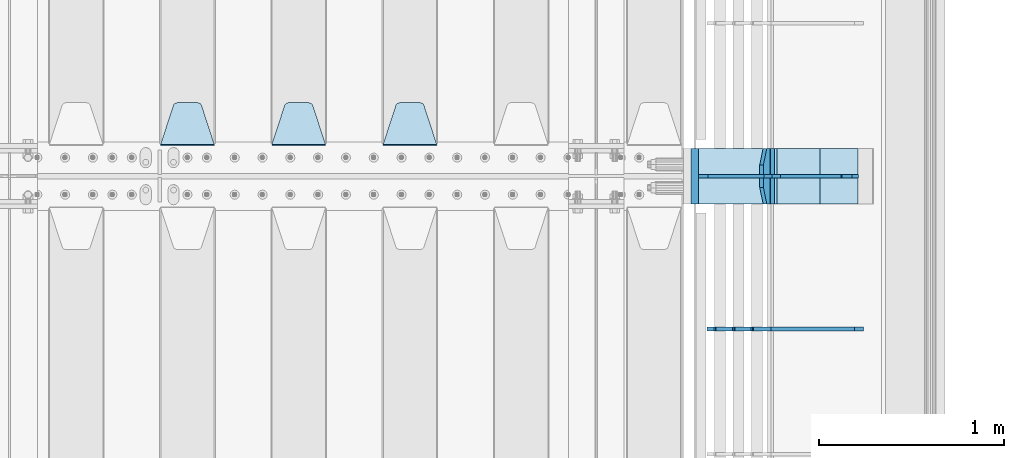
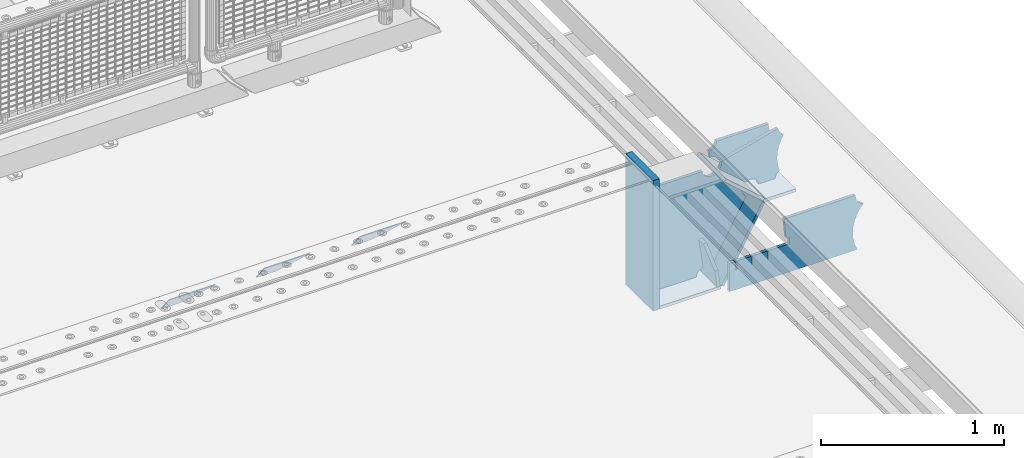
# One storey, part 221 of 240: 13 plates.
"""IFC2X3 building model written with IfcOpenShell, lengths in millimetres."""

from ifc_helpers import new_model, si_unit, frame, origin_with_axes, place, context, subcontext, project, spatial, faceted_brep, material, type_object, element, save


model = new_model("IFC2X3")

# Units and contexts
model_context = context("Model", 3, precision=1e-05, world=origin_with_axes())
body_context = subcontext(model_context, "Body", "Model", "MODEL_VIEW")
ifc_project = project(units=[si_unit("LENGTHUNIT", "METRE", prefix="MILLI"), si_unit("AREAUNIT", "SQUARE_METRE"), si_unit("VOLUMEUNIT", "CUBIC_METRE"), si_unit("MASSUNIT", "GRAM", prefix="KILO"), si_unit("TIMEUNIT", "SECOND"), si_unit("PLANEANGLEUNIT", "RADIAN"), si_unit("SOLIDANGLEUNIT", "STERADIAN"), si_unit("THERMODYNAMICTEMPERATUREUNIT", "DEGREE_CELSIUS"), si_unit("LUMINOUSINTENSITYUNIT", "LUMEN")], contexts=[model_context])

# Site, building, storey
site_placement = place(None, origin_with_axes())
site = spatial("IfcSite", under=ifc_project, at=site_placement, CompositionType="ELEMENT")
building_placement = place(site_placement, origin_with_axes())
building = spatial("IfcBuilding", under=site, at=building_placement, Name="Standard", CompositionType="ELEMENT")
storey_placement = place(building_placement, origin_with_axes())
storey = spatial("IfcBuildingStorey", under=building, at=storey_placement, Name="Undefined", CompositionType="ELEMENT", Elevation=0.0)

# Plates
ifc_material_1 = material(Name="STEEL/S355N")
plate_type_1 = type_object("IfcPlateType", PredefinedType="NOTDEFINED")
plate_1_placement = place(storey_placement, frame((55145.0, 33168.232233047, -1.76776695296758), z_axis=(0.0, 0.707106781186547, -0.707106781186548), x_axis=(-1.0, 0.0, 0.0)))
element("IfcPlate", 1, at=plate_1_placement, inside=storey, type_object=plate_type_1, material=ifc_material_1, context=body_context, shape_type="Brep", body=[
    faceted_brep([(0.0, -2.5, 0.0), (69.345504679477, -2.50000000000364, 300.171731424827), (69.345504679477, 2.49999999999636, 300.171731424827), (0.0, 2.5, 0.0), (70.927406119954, -2.50000000000364, 304.897442415397), (70.927406119954, 2.49999999999636, 304.897442415397), (73.3818627772271, -2.50000000000728, 309.234538108525), (73.3818627772271, 2.49999999999636, 309.234538108529), (76.6187032999587, -2.50000000000728, 313.023683126099), (76.6187032999587, 2.49999999999636, 313.023683126103), (80.5190132705029, -2.50000000000364, 316.125672595368), (80.5190132705029, 2.49999999999636, 316.125672595368), (84.9395038596849, -2.50000000000364, 318.426546230472), (84.9395038596849, 2.49999999999636, 318.426546230472), (89.7177759439219, -2.5, 319.841774983277), (89.7177759439219, 2.49999999999636, 319.841774983273), (94.6782862926484, -2.50000000000364, 320.319366455074), (94.6782862926484, 2.49999999999636, 320.319366455074), (195.321713707352, -2.50000000000364, 320.319366455074), (195.321713707352, 2.49999999999636, 320.319366455074), (200.282224056078, -2.50000000000364, 319.841774983273), (200.282224056078, 2.49999999999636, 319.841774983273), (205.060496140315, -2.50000000000364, 318.426546230472), (205.060496140315, 2.49999999999636, 318.426546230472), (209.480986729497, -2.50000000000364, 316.125672595368), (209.480986729497, 2.49999999999636, 316.125672595368), (213.381296700041, -2.50000000000728, 313.023683126099), (213.381296700041, 2.49999999999272, 313.023683126099), (216.618137222766, -2.50000000000364, 309.234538108522), (216.618137222766, 2.49999999999636, 309.234538108522), (219.072593880039, -2.50000000000364, 304.897442415397), (219.072593880039, 2.49999999999636, 304.897442415397), (220.654495320523, -2.50000000000364, 300.171731424827), (220.654495320523, 2.49999999999636, 300.171731424827), (290.0, -2.50000000000364, -3.63797880709171e-12), (290.0, 2.49999999999636, -3.63797880709171e-12)], [[[0, 1, 2, 3]], [[1, 4, 5, 2]], [[4, 6, 7, 5]], [[6, 8, 9, 7]], [[8, 10, 11, 9]], [[10, 12, 13, 11]], [[12, 14, 15, 13]], [[14, 16, 17, 15]], [[16, 18, 19, 17]], [[18, 20, 21, 19]], [[20, 22, 23, 21]], [[22, 24, 25, 23]], [[24, 26, 27, 25]], [[26, 28, 29, 27]], [[28, 30, 31, 29]], [[30, 32, 33, 31]], [[32, 34, 35, 33]], [[34, 0, 3, 35]], [[5, 7, 9, 11, 13, 15, 17, 19, 21, 23, 25, 27, 29, 31, 33, 35, 3, 2]], [[34, 32, 30, 28, 26, 24, 22, 20, 18, 16, 14, 12, 10, 8, 6, 4, 1, 0]]]),
])
plate_2_placement = place(storey_placement, frame((54545.0, 33168.232233047, -1.76776695296758), z_axis=(0.0, 0.707106781186547, -0.707106781186548), x_axis=(-1.0, 0.0, 0.0)))
element("IfcPlate", 2, at=plate_2_placement, inside=storey, type_object=plate_type_1, material=ifc_material_1, context=body_context, shape_type="Brep", body=[
    faceted_brep([(0.0, -2.5, 0.0), (69.345504679477, -2.50000000000364, 300.171731424827), (69.345504679477, 2.49999999999636, 300.171731424827), (0.0, 2.5, 0.0), (70.927406119954, -2.50000000000364, 304.897442415397), (70.927406119954, 2.49999999999636, 304.897442415397), (73.3818627772271, -2.50000000000728, 309.234538108525), (73.3818627772271, 2.49999999999636, 309.234538108529), (76.6187032999587, -2.50000000000728, 313.023683126099), (76.6187032999587, 2.49999999999636, 313.023683126103), (80.5190132705029, -2.50000000000364, 316.125672595368), (80.5190132705029, 2.49999999999636, 316.125672595368), (84.9395038596849, -2.50000000000364, 318.426546230472), (84.9395038596849, 2.49999999999636, 318.426546230472), (89.7177759439219, -2.5, 319.841774983277), (89.7177759439219, 2.49999999999636, 319.841774983273), (94.6782862926484, -2.50000000000364, 320.319366455074), (94.6782862926484, 2.49999999999636, 320.319366455074), (195.321713707352, -2.50000000000364, 320.319366455074), (195.321713707352, 2.49999999999636, 320.319366455074), (200.282224056078, -2.50000000000364, 319.841774983273), (200.282224056078, 2.49999999999636, 319.841774983273), (205.060496140315, -2.50000000000364, 318.426546230472), (205.060496140315, 2.49999999999636, 318.426546230472), (209.480986729497, -2.50000000000364, 316.125672595368), (209.480986729497, 2.49999999999636, 316.125672595368), (213.381296700041, -2.50000000000728, 313.023683126099), (213.381296700041, 2.49999999999272, 313.023683126099), (216.618137222766, -2.50000000000364, 309.234538108522), (216.618137222766, 2.49999999999636, 309.234538108522), (219.072593880039, -2.50000000000364, 304.897442415397), (219.072593880039, 2.49999999999636, 304.897442415397), (220.654495320523, -2.50000000000364, 300.171731424827), (220.654495320523, 2.49999999999636, 300.171731424827), (290.0, -2.50000000000364, -3.63797880709171e-12), (290.0, 2.49999999999636, -3.63797880709171e-12)], [[[0, 1, 2, 3]], [[1, 4, 5, 2]], [[4, 6, 7, 5]], [[6, 8, 9, 7]], [[8, 10, 11, 9]], [[10, 12, 13, 11]], [[12, 14, 15, 13]], [[14, 16, 17, 15]], [[16, 18, 19, 17]], [[18, 20, 21, 19]], [[20, 22, 23, 21]], [[22, 24, 25, 23]], [[24, 26, 27, 25]], [[26, 28, 29, 27]], [[28, 30, 31, 29]], [[30, 32, 33, 31]], [[32, 34, 35, 33]], [[34, 0, 3, 35]], [[5, 7, 9, 11, 13, 15, 17, 19, 21, 23, 25, 27, 29, 31, 33, 35, 3, 2]], [[34, 32, 30, 28, 26, 24, 22, 20, 18, 16, 14, 12, 10, 8, 6, 4, 1, 0]]]),
])
plate_3_placement = place(storey_placement, frame((53945.0, 33168.232233047, -1.76776695296758), z_axis=(0.0, 0.707106781186547, -0.707106781186548), x_axis=(-1.0, 0.0, 0.0)))
element("IfcPlate", 3, at=plate_3_placement, inside=storey, type_object=plate_type_1, material=ifc_material_1, context=body_context, shape_type="Brep", body=[
    faceted_brep([(0.0, -2.5, 0.0), (69.345504679477, -2.50000000000364, 300.171731424827), (69.345504679477, 2.49999999999636, 300.171731424827), (0.0, 2.5, 0.0), (70.927406119954, -2.50000000000364, 304.897442415397), (70.927406119954, 2.49999999999636, 304.897442415397), (73.3818627772271, -2.50000000000728, 309.234538108525), (73.3818627772271, 2.49999999999636, 309.234538108529), (76.6187032999587, -2.50000000000728, 313.023683126099), (76.6187032999587, 2.49999999999636, 313.023683126103), (80.5190132705029, -2.50000000000364, 316.125672595368), (80.5190132705029, 2.49999999999636, 316.125672595368), (84.9395038596849, -2.50000000000364, 318.426546230472), (84.9395038596849, 2.49999999999636, 318.426546230472), (89.7177759439219, -2.5, 319.841774983277), (89.7177759439219, 2.49999999999636, 319.841774983273), (94.6782862926484, -2.50000000000364, 320.319366455074), (94.6782862926484, 2.49999999999636, 320.319366455074), (195.321713707352, -2.50000000000364, 320.319366455074), (195.321713707352, 2.49999999999636, 320.319366455074), (200.282224056078, -2.50000000000364, 319.841774983273), (200.282224056078, 2.49999999999636, 319.841774983273), (205.060496140315, -2.50000000000364, 318.426546230472), (205.060496140315, 2.49999999999636, 318.426546230472), (209.480986729497, -2.50000000000364, 316.125672595368), (209.480986729497, 2.49999999999636, 316.125672595368), (213.381296700041, -2.50000000000728, 313.023683126099), (213.381296700041, 2.49999999999272, 313.023683126099), (216.618137222766, -2.50000000000364, 309.234538108522), (216.618137222766, 2.49999999999636, 309.234538108522), (219.072593880039, -2.50000000000364, 304.897442415397), (219.072593880039, 2.49999999999636, 304.897442415397), (220.654495320523, -2.50000000000364, 300.171731424827), (220.654495320523, 2.49999999999636, 300.171731424827), (290.0, -2.50000000000364, -3.63797880709171e-12), (290.0, 2.49999999999636, -3.63797880709171e-12)], [[[0, 1, 2, 3]], [[1, 4, 5, 2]], [[4, 6, 7, 5]], [[6, 8, 9, 7]], [[8, 10, 11, 9]], [[10, 12, 13, 11]], [[12, 14, 15, 13]], [[14, 16, 17, 15]], [[16, 18, 19, 17]], [[18, 20, 21, 19]], [[20, 22, 23, 21]], [[22, 24, 25, 23]], [[24, 26, 27, 25]], [[26, 28, 29, 27]], [[28, 30, 31, 29]], [[30, 32, 33, 31]], [[32, 34, 35, 33]], [[34, 0, 3, 35]], [[5, 7, 9, 11, 13, 15, 17, 19, 21, 23, 25, 27, 29, 31, 33, 35, 3, 2]], [[34, 32, 30, 28, 26, 24, 22, 20, 18, 16, 14, 12, 10, 8, 6, 4, 1, 0]]]),
])
plate_type_2 = type_object("IfcPlateType", PredefinedType="NOTDEFINED")
plate_4_placement = place(storey_placement, frame((56931.0775331946, 33150.0000000017, -871.412303810021), z_axis=(0.0, -1.0, 0.0), x_axis=(-0.137902988002476, 0.0, 0.990445741017643)))
element("IfcPlate", 4, at=plate_4_placement, inside=storey, type_object=plate_type_2, material=ifc_material_1, context=body_context, shape_type="Brep", body=[
    faceted_brep([(0.0, -10.0, 0.0), (-1.98269844986498e-10, -10.0, 300.0), (-1.98269844986498e-10, 10.0, 300.0), (0.0, 10.0, 0.0), (115.0, -10.0, 300.0), (115.0, 10.0, 300.0), (250.0, -10.0, 210.0), (250.0, 10.0, 210.0), (250.0, -10.0, 90.0), (250.0, 10.0, 90.0), (115.0, -10.0, -1.09139364212751e-10), (115.0, 10.0, -1.09139364212751e-10)], [[[0, 1, 2, 3]], [[1, 4, 5, 2]], [[4, 6, 7, 5]], [[6, 8, 9, 7]], [[8, 10, 11, 9]], [[10, 0, 3, 11]], [[5, 7, 9, 11, 3, 2]], [[10, 8, 6, 4, 1, 0]]]),
])
plate_type_3 = type_object("IfcPlateType", PredefinedType="NOTDEFINED")
plate_5_placement = place(storey_placement, frame((56959.9988298913, 33000.0000000001, -179.999999999866), z_axis=(0.0, 0.0, -1.0), x_axis=(-1.0, 0.0, 0.0)))
element("IfcPlate", 5, at=plate_5_placement, inside=storey, type_object=plate_type_3, material=ifc_material_1, context=body_context, shape_type="Brep", body=[
    faceted_brep([(46.0258547361809, 10.0, 641.078828352491), (73.3015011075258, 10.0000000000146, 445.179898435806), (73.3015011075258, -9.99999999998545, 445.179898435806), (46.0258547361809, -10.0, 641.078828352491), (53.4925862871751, 10.0000000000146, 442.421838675757), (53.4925862871751, -9.99999999998545, 442.421838675757), (25.782050112437, 10.0, 641.444230671302), (25.782050112437, -10.0, 641.444230671302), (54.6652503111691, 10.0, 642.447174185377), (54.6652503111691, -10.0, 642.447174185377), (68.6036632070463, -10.0, 649.549150281387), (68.6036632070463, 10.0, 649.549150281387), (79.6652503111691, -10.0, 660.610737385511), (79.6652503111691, 10.0, 660.610737385511), (86.7672264071807, -10.0, 674.549150281387), (86.7672264071807, 10.0, 674.549150281387), (89.2144005924201, -10.0, 690.0), (89.2144005924201, 10.0, 690.0), (353.0, -10.0, 690.0), (353.0, 10.0, 690.0), (355.447174185239, -10.0, 674.549150281253), (355.447174185239, 10.0, 674.549150281253), (362.549150281251, -10.0, 660.610737385376), (362.549150281251, 10.0, 660.610737385376), (373.610737385374, -10.0, 649.549150281253), (373.610737385374, 10.0, 649.549150281253), (387.549150281251, -10.0, 642.447174185242), (387.549150281251, 10.0, 642.447174185242), (403.0, -10.0, 640.0), (403.0, 10.0, 640.0), (403.0, -10.0, 50.0), (403.0, 10.0, 50.0), (387.549150281251, -10.0, 47.5528258147577), (387.549150281251, 10.0, 47.5528258147577), (373.610737385374, -10.0, 40.4508497187474), (373.610737385374, 10.0, 40.4508497187474), (362.549150281251, -10.0, 29.3892626146236), (362.549150281251, 10.0, 29.3892626146236), (355.447174185239, -10.0, 15.4508497187474), (355.447174185239, 10.0, 15.4508497187474), (353.0, -10.0, 0.0), (353.0, 10.0, 0.0), (50.0, -10.0, 0.0), (50.0, 10.0, 0.0), (47.0349915316328, -10.0, 16.9620037619133), (47.0349915316328, 10.0, 16.9620037619133), (38.4916171352306, -10.0, 31.9123081320451), (38.4916171352306, 10.0, 31.9123081320451), (25.3831239081483, -10.0, 43.0778019479116), (25.3831239081483, 10.0, 43.0778019479116), (9.26418358741648, -10.0, 49.1342538608113), (9.26418358741648, 10.0, 49.1342538608113), (-7.95349204488593, -10.0, 49.363366622344), (-7.95349204488593, 10.0, 49.363366622344), (-24.2278808265401, -10.0, 43.7379673813837), (-24.2278808265401, 10.0, 43.7379673813837), (-37.6288347353475, -10.0, 32.9252303934259), (-37.6288347353475, 10.0, 32.9252303934259), (-210.371165264653, -10.0, 184.074769606574), (-210.371165264653, 10.0, 184.074769606574), (-202.382363280565, -10.0, 196.529747922069), (-202.382363280565, 10.0, 196.529747922069), (-198.388707244048, -10.0, 210.777489969227), (-198.388707244048, 10.0, 210.777489969227), (-198.73995746443, -10.0, 225.570193077959), (-198.73995746443, 10.0, 225.570193077959), (-203.40535180681, -10.0, 239.612327446012), (-203.40535180681, 10.0, 239.612327446012), (-211.976299808361, -10.0, 251.674097313455), (-211.976299808361, 10.0, 251.674097313455), (-223.702166612966, -10.0, 260.699145216992), (-223.702166612966, 10.0, 260.699145216992), (-9.29783338703419, -10.0, 646.300854783008), (-9.29783338703419, 10.0, 646.300854783008), (6.98069453598146, -10.0, 640.647282345602), (6.98069453598146, 10.0, 640.647282345602), (24.2117663163663, -10.0, 640.855891896051), (24.2117663163663, 10.0, 640.855891896051)], [[[0, 1, 2, 3]], [[4, 5, 2, 1]], [[6, 7, 5, 4]], [[8, 9, 10, 11]], [[11, 10, 12, 13]], [[13, 12, 14, 15]], [[15, 14, 16, 17]], [[18, 19, 17, 16]], [[18, 20, 21, 19]], [[20, 22, 23, 21]], [[22, 24, 25, 23]], [[24, 26, 27, 25]], [[26, 28, 29, 27]], [[28, 30, 31, 29]], [[30, 32, 33, 31]], [[32, 34, 35, 33]], [[34, 36, 37, 35]], [[36, 38, 39, 37]], [[38, 40, 41, 39]], [[40, 42, 43, 41]], [[42, 44, 45, 43]], [[44, 46, 47, 45]], [[46, 48, 49, 47]], [[48, 50, 51, 49]], [[50, 52, 53, 51]], [[52, 54, 55, 53]], [[54, 56, 57, 55]], [[56, 58, 59, 57]], [[58, 60, 61, 59]], [[60, 62, 63, 61]], [[62, 64, 65, 63]], [[64, 66, 67, 65]], [[66, 68, 69, 67]], [[68, 70, 71, 69]], [[70, 72, 73, 71]], [[72, 74, 75, 73]], [[74, 76, 77, 75]], [[1, 0, 8, 11, 13, 15, 17, 19, 21, 23, 25, 27, 29, 31, 33, 35, 37, 39, 41, 43, 45, 47, 49, 51, 53, 55, 57, 59, 61, 63, 65, 67, 69, 71, 73, 75, 77, 6, 4]], [[9, 8, 0, 3]], [[76, 74, 72, 70, 68, 66, 64, 62, 60, 58, 56, 54, 52, 50, 48, 46, 44, 42, 40, 38, 36, 34, 32, 30, 28, 26, 24, 22, 20, 18, 16, 14, 12, 10, 9, 3, 2, 5, 7]], [[77, 76, 7, 6]]]),
])
plate_type_4 = type_object("IfcPlateType", PredefinedType="NOTDEFINED")
plate_6_placement = place(storey_placement, frame((57500.9988502512, 32999.9999999993, -28.9999913318487), z_axis=(0.260769276985653, 0.0, -0.965401151946889), x_axis=(-0.965401151946889, 0.0, -0.260769276985654)))
element("IfcPlate", 6, at=plate_6_placement, inside=storey, type_object=plate_type_4, material=ifc_material_1, context=body_context, shape_type="Brep", body=[
    faceted_brep([(183.436474692309, 10.0, 275.852500330424), (184.91838860904, 10.0, 264.41784353133), (184.91838860904, -10.0, 264.41784353133), (183.436474692309, -10.0, 275.852500330424), (183.794583267605, 10.0, 224.576469334612), (183.794583267605, -10.0, 224.576469334612), (176.45204977582, 10.0, 185.401410454628), (176.45204977582, -10.0, 185.401410454628), (163.071585676764, 10.0, 147.857286855562), (163.071585676764, -10.0, 147.857286855562), (143.982662403731, 10.0, 112.868559462233), (143.982662403731, -10.0, 112.868559462233), (119.655312600233, 10.0, 81.2967668639885), (119.655312600233, -10.0, 81.2967668639885), (100.960891712748, 10.0, 63.6280409830943), (100.960891712748, -10.0, 63.6280409830943), (194.486836975891, -10.0, 278.751956446691), (207.178624553366, -10.0, 286.650994937518), (207.178624553366, 10.0, 286.650994937518), (194.486836975891, 10.0, 278.751956446691), (216.968013469435, -10.0, 297.948965801399), (216.968013469435, 10.0, 297.948965801399), (222.979925232852, -10.0, 311.635937633771), (222.979925232852, 10.0, 311.635937633771), (323.381647032758, -10.0, 284.515917834986), (323.381647032758, 10.0, 284.515917834986), (321.720617177329, -10.0, 268.853198956864), (321.720617177329, 10.0, 268.853198956864), (325.014344481133, -10.0, 253.450889283185), (325.014344481133, 10.0, 253.450889283185), (332.935986082477, -10.0, 239.837389469556), (332.935986082477, 10.0, 239.837389469556), (344.699462330085, -10.0, 229.363593146938), (344.699462330085, 10.0, 229.363593146938), (359.1374609708, -10.0, 223.068835162203), (359.1374609708, 10.0, 223.068835162203), (374.817271777676, -10.0, 221.577756392893), (374.817271777676, 10.0, 221.577756392893), (390.182952880852, -10.0, 225.03833007813), (390.182952880852, 10.0, 225.03833007813), (512.909060513019, -10.0, 41.5599003357038), (512.909060513019, 10.0, 41.5599003357038), (503.648024844573, -10.0, 33.564366674771), (503.648024844573, 10.0, 33.564366674771), (496.6060645697, -10.0, 23.5590612990018), (496.6060645697, 10.0, 23.5590612990018), (492.204839143924, -10.0, 12.1430832451115), (492.204839143924, 10.0, 12.1430832451115), (490.707885742188, -10.0, 3.8198777474463e-10), (490.707885742188, 10.0, 3.8198777474463e-10), (119.999999999993, -10.0, 9.64064383879304e-11), (119.999999999993, 10.0, 9.64064383879304e-11), (117.226254779103, -10.0, 25.6516118492182), (117.226254779103, 10.0, 25.6516118492182), (109.033246825653, -10.0, 50.1173731021008), (109.033246825653, 10.0, 50.1173731021008)], [[[0, 1, 2, 3]], [[4, 5, 2, 1]], [[6, 7, 5, 4]], [[8, 9, 7, 6]], [[10, 11, 9, 8]], [[12, 13, 11, 10]], [[14, 15, 13, 12]], [[16, 17, 18, 19]], [[17, 20, 21, 18]], [[20, 22, 23, 21]], [[22, 24, 25, 23]], [[24, 26, 27, 25]], [[26, 28, 29, 27]], [[28, 30, 31, 29]], [[30, 32, 33, 31]], [[32, 34, 35, 33]], [[34, 36, 37, 35]], [[36, 38, 39, 37]], [[38, 40, 41, 39]], [[40, 42, 43, 41]], [[42, 44, 45, 43]], [[44, 46, 47, 45]], [[46, 48, 49, 47]], [[48, 50, 51, 49]], [[50, 52, 53, 51]], [[52, 54, 55, 53]], [[10, 8, 6, 4, 1, 0, 19, 18, 21, 23, 25, 27, 29, 31, 33, 35, 37, 39, 41, 43, 45, 47, 49, 51, 53, 55, 14, 12]], [[16, 19, 0, 3]], [[54, 52, 50, 48, 46, 44, 42, 40, 38, 36, 34, 32, 30, 28, 26, 24, 22, 20, 17, 16, 3, 2, 5, 7, 9, 11, 13, 15]], [[55, 54, 15, 14]]]),
])
plate_type_5 = type_object("IfcPlateType", PredefinedType="NOTDEFINED")
plate_7_placement = place(storey_placement, frame((56972.2260590443, 33149.9999999993, -177.219372761326), z_axis=(0.752414935148685, 0.0, -0.658689430130164), x_axis=(0.0, -1.0, 0.0)))
element("IfcPlate", 7, at=plate_7_placement, inside=storey, type_object=plate_type_5, material=ifc_material_1, context=body_context, shape_type="Brep", body=[
    faceted_brep([(0.0, -10.0, 0.0), (1.09139364212751e-10, -10.0000000000073, 319.999999999993), (1.09139364212751e-10, 10.0, 319.999999999993), (0.0, 10.0, 0.0), (300.0, -10.0000000000073, 319.999999999993), (300.0, 10.0, 319.999999999993), (300.0, -10.0, 5.82076609134674e-11), (300.0, 10.0, 5.82076609134674e-11)], [[[0, 1, 2, 3]], [[1, 4, 5, 2]], [[4, 6, 7, 5]], [[6, 0, 3, 7]], [[5, 7, 3, 2]], [[6, 4, 1, 0]]]),
])
plate_8_placement = place(storey_placement, frame((57213.0007288108, 33150.0000000001, -408.004820491625), z_axis=(-0.484064236150485, 0.0, -0.875032465272031), x_axis=(0.0, -1.0, 0.0)))
element("IfcPlate", 8, at=plate_8_placement, inside=storey, type_object=plate_type_5, material=ifc_material_1, context=body_context, shape_type="Brep", body=[
    faceted_brep([(0.0, -10.0, 0.0), (3.86513420380652e-07, -10.0, 533.528442382813), (3.86513420380652e-07, 9.99999999999272, 533.528442382809), (0.0, 10.0, 0.0), (300.003295898438, -10.0000000000073, 533.549133300778), (300.003295898438, 10.0, 533.549133300781), (300.0, -10.0, 5.82076609134674e-11), (300.0, 10.0, 5.82076609134674e-11)], [[[0, 1, 2, 3]], [[1, 4, 5, 2]], [[4, 6, 7, 5]], [[6, 0, 3, 7]], [[5, 7, 3, 2]], [[6, 4, 1, 0]]]),
])
plate_9_placement = place(storey_placement, frame((56556.9988298913, 33150.0000000001, -879.999999999866), z_axis=(0.0, -1.0, 0.0), x_axis=(1.0, 0.0, 0.0)))
element("IfcPlate", 9, at=plate_9_placement, inside=storey, type_object=plate_type_5, material=ifc_material_1, context=body_context, shape_type="Brep", body=[
    faceted_brep([(0.0, -10.0, 0.0), (-1.98269844986498e-10, -10.0, 300.0), (-1.98269844986498e-10, 10.0, 300.0), (0.0, 10.0, 0.0), (389.0, -10.0, 300.0), (389.0, 10.0, 300.0), (389.0, -10.0, 0.0), (389.0, 10.0, 0.0)], [[[0, 1, 2, 3]], [[1, 4, 5, 2]], [[4, 6, 7, 5]], [[6, 0, 3, 7]], [[5, 7, 3, 2]], [[6, 4, 1, 0]]]),
])
plate_type_6 = type_object("IfcPlateType", PredefinedType="NOTDEFINED")
plate_10_placement = place(storey_placement, frame((57416.9988298913, 33149.9999999993, -397.999999999763), z_axis=(-1.0, 0.0, 0.0), x_axis=(0.0, -1.0, 0.0)))
element("IfcPlate", 10, at=plate_10_placement, inside=storey, type_object=plate_type_6, material=ifc_material_1, context=body_context, shape_type="Brep", body=[
    faceted_brep([(0.0, -10.0, 0.0), (4.65661287307739e-10, -10.0, 204.0), (4.65661287307739e-10, 10.0, 204.0), (0.0, 10.0, 0.0), (300.0, -10.0, 204.0), (300.0, 10.0, 204.0), (300.0, -10.0, 5.82076609134674e-11), (300.0, 10.0, 5.82076609134674e-11)], [[[0, 1, 2, 3]], [[1, 4, 5, 2]], [[4, 6, 7, 5]], [[6, 0, 3, 7]], [[5, 7, 3, 2]], [[6, 4, 1, 0]]]),
])
ifc_material_2 = material()
plate_type_7 = type_object("IfcPlateType", PredefinedType="NOTDEFINED")
plate_11_placement = place(storey_placement, frame((56536.9988298906, 33150.0, -889.999999999995), z_axis=(0.0, 0.0, 1.0), x_axis=(0.0, -1.0, 0.0)))
element("IfcPlate", 11, at=plate_11_placement, inside=storey, type_object=plate_type_7, material=ifc_material_2, context=body_context, shape_type="Brep", body=[
    faceted_brep([(0.0, -20.0, 0.0), (0.0, -20.0, 870.0), (0.0, 20.0, 870.0), (0.0, 20.0, 0.0), (300.0, -20.0, 870.0), (300.0, 20.0, 870.0), (300.0, -20.0, -1.81898940354586e-12), (300.0, 20.0, -1.81898940354586e-12)], [[[0, 1, 2, 3]], [[1, 4, 5, 2]], [[4, 6, 7, 5]], [[6, 0, 3, 7]], [[5, 7, 3, 2]], [[6, 4, 1, 0]]]),
])
plate_type_8 = type_object("IfcPlateType", PredefinedType="NOTDEFINED")
plate_12_placement = place(storey_placement, frame((57495.9988298906, 33000.0, -9.99999999999716), z_axis=(0.0, 0.0, -1.0), x_axis=(-1.0, 0.0, 0.0)))
element("IfcPlate", 12, at=plate_12_placement, inside=storey, type_object=plate_type_8, material=ifc_material_1, context=body_context, shape_type="Brep", body=[
    faceted_brep([(164.157641141064, -10.0, 44.1844865875018), (486.71834084086, -10.0, 131.004562768382), (486.71834084086, 10.0, 131.004562768382), (164.157641141064, 10.0, 44.1844865875018), (492.179177700767, -10.0, 118.185717565315), (492.179177700767, 10.0, 118.185717565315), (500.965368826706, -10.0, 107.371542744776), (500.965368826706, 10.0, 107.371542744776), (512.394601349042, -10.0, 99.4018391429503), (512.394601349042, 10.0, 99.4018391429503), (525.579310641864, -10.0, 94.8955133209048), (525.579310641864, 10.0, 94.8955133209048), (539.495606295335, -10.0, 94.2025148824028), (539.495606295335, 10.0, 94.2025148824028), (543.504393704665, -10.0, 49.7974851175972), (543.504393704665, 10.0, 49.7974851175972), (529.167086307512, -10.0, 46.3176139481669), (529.167086307512, 10.0, 46.3176139481669), (516.469507120331, -10.0, 38.8049999196639), (516.469507120331, 10.0, 38.8049999196639), (506.517198234542, -10.0, 27.9137449599276), (506.517198234542, 10.0, 27.9137449599276), (500.17667886756, -10.0, 14.592119649441), (500.17667886756, 10.0, 14.592119649441), (498.0, -10.0, 0.0), (498.0, 10.0, 0.0), (170.0, -10.0, 0.0), (170.0, 10.0, 0.0), (169.632873911985, -10.0, 11.1663820622718), (169.632873911985, 10.0, 11.1663820622718), (168.533081313406, -10.0, 22.2845350637931), (168.533081313406, 10.0, 22.2845350637931), (166.705372351957, -10.0, 33.3064382514178), (166.705372351957, 10.0, 33.3064382514178)], [[[0, 1, 2, 3]], [[1, 4, 5, 2]], [[4, 6, 7, 5]], [[6, 8, 9, 7]], [[8, 10, 11, 9]], [[10, 12, 13, 11]], [[12, 14, 15, 13]], [[14, 16, 17, 15]], [[16, 18, 19, 17]], [[18, 20, 21, 19]], [[20, 22, 23, 21]], [[22, 24, 25, 23]], [[24, 26, 27, 25]], [[26, 28, 29, 27]], [[28, 30, 31, 29]], [[30, 32, 33, 31]], [[32, 0, 3, 33]], [[5, 7, 9, 11, 13, 15, 17, 19, 21, 23, 25, 27, 29, 31, 33, 3, 2]], [[32, 30, 28, 26, 24, 22, 20, 18, 16, 14, 12, 10, 8, 6, 4, 1, 0]]]),
])
plate_type_9 = type_object("IfcPlateType", PredefinedType="NOTDEFINED")
plate_13_placement = place(storey_placement, frame((57442.9182339676, 32174.9992828369, -374.002067436516), z_axis=(0.0, 0.0, 1.0), x_axis=(-1.0, 0.0, 0.0)))
element("IfcPlate", 13, at=plate_13_placement, inside=storey, type_object=plate_type_9, material=ifc_material_1, context=body_context, shape_type="Brep", body=[
    faceted_brep([(801.919404066546, -10.0, 188.0), (801.919404066546, 10.0, 188.0), (801.919404066546, 10.0, 132.002067436952), (801.919404066546, -10.0, 132.002067436952), (793.919404066546, 10.0, 132.002067436952), (793.919404066546, -10.0, 132.002067436952), (793.919404066546, 10.0, 180.002067436952), (793.919404066546, -10.0, 180.002067436952), (793.52785619691, 10.0, 182.474203391951), (793.52785619691, -10.0, 182.474203391951), (792.391540021548, 10.0, 184.704349455291), (792.391540021548, -10.0, 184.704349455291), (790.621686084887, 10.0, 186.474203391951), (790.621686084887, -10.0, 186.474203391951), (788.391540021548, 10.0, 187.610519567313), (788.391540021548, -10.0, 187.610519567313), (785.919404066546, -10.0, 188.002067436952), (785.919404066546, 10.0, 188.0), (841.0, -10.0, 188.0), (841.0, -10.0, 0.0), (841.0, 10.0, 0.0), (841.0, 10.0, 188.0), (33.3619566735943, -10.0, 0.0), (33.3619566735943, 10.0, 0.0), (36.2350612208102, -10.0, 4.68848050267013), (36.2350612208102, 10.0, 4.68848050267013), (51.4877592159319, -10.0, 41.5117508652784), (51.4877592159319, 10.0, 41.5117508652784), (60.7922425881334, -10.0, 80.2677133162964), (60.7922425881334, 10.0, 80.2677133162964), (63.9194040769653, -10.0, 120.002067436515), (63.9194040769653, 10.0, 120.002067436515), (60.7922425881334, -10.0, 159.736421556734), (60.7922425881334, 10.0, 159.736421556734), (51.4877592159319, -10.0, 198.492384007752), (51.4877592159319, 10.0, 198.492384007752), (36.2350612208102, -10.0, 235.31565437036), (36.2350612208102, 10.0, 235.31565437036), (15.4097206482038, -10.0, 269.299521518803), (15.4097206482038, 10.0, 269.299521518803), (-3.35474438100209, -10.0, 291.269887256574), (-3.35474438100209, 10.0, 291.269887256574), (-2.36881039375294, -10.0000000000036, 291.426043859339), (-2.36881039375294, 10.0, 291.426043859339), (17.1449676604752, -10.0000000000036, 301.368810393754), (17.1449676604752, 10.0, 301.368810393754), (32.6311896062471, -10.0000000000036, 316.855032339527), (32.6311896062471, 10.0, 316.855032339527), (42.573956140659, -10.0000000000036, 336.368810393754), (42.573956140659, 10.0, 336.368810393754), (46.0, -10.0000000000036, 358.0), (46.0, 10.0, 358.0), (45.0495205499246, -10.0, 364.001091067617), (45.0495205499246, 10.0, 364.001091067617), (495.040008544922, -10.0, 364.010009765625), (495.040008544922, 10.0, 364.010009765625), (483.600036621094, -10.0, 233.759994506836), (483.600036621094, 10.0, 233.759994506836), (472.0, -10.0, 233.759994506836), (472.0, 10.0, 233.759994506836), (468.909830056247, -10.0, 233.270559669787), (468.909830056247, 10.0, 233.270559669787), (466.122147477072, -10.0, 231.850164450585), (466.122147477072, 10.0, 231.850164450585), (463.909830056247, -10.0, 229.637847029761), (463.909830056247, 10.0, 229.637847029761), (462.489434837051, -10.0, 226.850164450585), (462.489434837051, 10.0, 226.850164450585), (462.0, -10.0, 223.759994506836), (462.0, 10.0, 223.759994506836), (462.0, -10.0, 198.0), (462.0, 10.0, 198.0), (462.489434837051, -10.0, 194.909830056251), (462.489434837051, 10.0, 194.909830056251), (463.909830056247, -10.0, 192.122147477075), (463.909830056247, 10.0, 192.122147477075), (466.122147477072, -10.0, 189.909830056251), (466.122147477072, 10.0, 189.909830056251), (468.909830056247, -10.0, 188.489434837048), (468.909830056247, 10.0, 188.489434837048), (472.0, -10.0, 188.0), (472.0, 10.0, 188.0), (585.919404066546, -10.0, 188.002067436952), (585.919404066546, 10.0, 188.0), (588.391540021548, -9.99999999999636, 187.610519567313), (588.391540021548, 10.0, 187.610519567313), (590.621686084887, -9.99999999999636, 186.474203391951), (590.621686084887, 10.0, 186.474203391951), (592.391540021548, -9.99999999999636, 184.704349455291), (592.391540021548, 10.0, 184.704349455291), (593.52785619691, -9.99999999999636, 182.474203391951), (593.52785619691, 10.0, 182.474203391951), (593.919404066546, -9.99999999999636, 180.002067436952), (593.919404066546, 10.0, 180.002067436952), (593.919404066546, -9.99999999999636, 132.002067436952), (593.919404066546, 10.0, 132.002067436952), (601.919404066546, -9.99999999999636, 132.002067436952), (601.919404066546, 10.0, 132.002067436952), (601.919404066546, -10.0, 188.0), (601.919404066546, 10.0, 188.0), (685.919404066546, -10.0, 188.002067436952), (685.919404066546, 10.0, 188.0), (688.391540021548, -10.0, 187.610519567313), (688.391540021548, 10.0, 187.610519567313), (690.621686084887, -10.0, 186.474203391951), (690.621686084887, 10.0, 186.474203391951), (692.391540021548, -10.0, 184.704349455291), (692.391540021548, 10.0, 184.704349455291), (693.52785619691, -10.0, 182.474203391951), (693.52785619691, 10.0, 182.474203391951), (693.919404066546, -10.0, 180.002067436952), (693.919404066546, 10.0, 180.002067436952), (693.919404066546, -10.0, 132.002067436952), (693.919404066546, 10.0000000000036, 132.002067436952), (701.919404066546, -10.0, 132.002067436952), (701.919404066546, 10.0000000000036, 132.002067436952), (701.919404066546, -10.0, 188.0), (701.919404066546, 10.0, 188.0)], [[[0, 1, 2, 3]], [[3, 2, 4, 5]], [[5, 4, 6, 7]], [[7, 6, 8, 9]], [[9, 8, 10, 11]], [[11, 10, 12, 13]], [[13, 12, 14, 15]], [[16, 15, 14, 17]], [[18, 19, 20, 21]], [[20, 19, 22, 23]], [[22, 24, 25, 23]], [[26, 27, 25, 24]], [[28, 29, 27, 26]], [[30, 31, 29, 28]], [[32, 33, 31, 30]], [[34, 35, 33, 32]], [[36, 37, 35, 34]], [[38, 39, 37, 36]], [[39, 38, 40, 41]], [[40, 42, 43, 41]], [[44, 45, 43, 42]], [[46, 47, 45, 44]], [[48, 49, 47, 46]], [[50, 51, 49, 48]], [[52, 53, 51, 50]], [[54, 55, 53, 52]], [[54, 56, 57, 55]], [[56, 58, 59, 57]], [[58, 60, 61, 59]], [[60, 62, 63, 61]], [[62, 64, 65, 63]], [[64, 66, 67, 65]], [[66, 68, 69, 67]], [[68, 70, 71, 69]], [[70, 72, 73, 71]], [[72, 74, 75, 73]], [[74, 76, 77, 75]], [[76, 78, 79, 77]], [[78, 80, 81, 79]], [[81, 80, 82, 83]], [[82, 84, 85, 83]], [[86, 87, 85, 84]], [[88, 89, 87, 86]], [[90, 91, 89, 88]], [[92, 93, 91, 90]], [[94, 95, 93, 92]], [[96, 97, 95, 94]], [[98, 99, 97, 96]], [[99, 98, 100, 101]], [[100, 102, 103, 101]], [[104, 105, 103, 102]], [[106, 107, 105, 104]], [[108, 109, 107, 106]], [[110, 111, 109, 108]], [[112, 113, 111, 110]], [[114, 115, 113, 112]], [[116, 117, 115, 114]], [[117, 116, 16, 17]], [[12, 10, 8, 6, 4, 2, 1, 21, 20, 23, 25, 27, 29, 31, 33, 35, 37, 39, 41, 43, 45, 47, 49, 51, 53, 55, 57, 59, 61, 63, 65, 67, 69, 71, 73, 75, 77, 79, 81, 83, 85, 87, 89, 91, 93, 95, 97, 99, 101, 103, 105, 107, 109, 111, 113, 115, 117, 17, 14]], [[18, 21, 1, 0]], [[116, 114, 112, 110, 108, 106, 104, 102, 100, 98, 96, 94, 92, 90, 88, 86, 84, 82, 80, 78, 76, 74, 72, 70, 68, 66, 64, 62, 60, 58, 56, 54, 52, 50, 48, 46, 44, 42, 40, 38, 36, 34, 32, 30, 28, 26, 24, 22, 19, 18, 0, 3, 5, 7, 9, 11, 13, 15, 16]]]),
])

save(model, "model.ifc")
